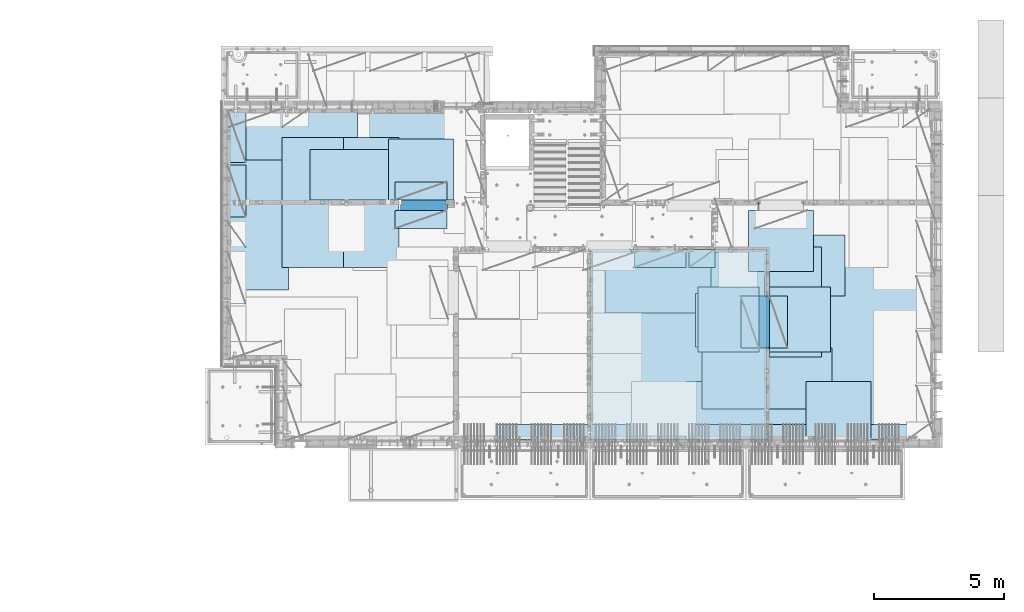
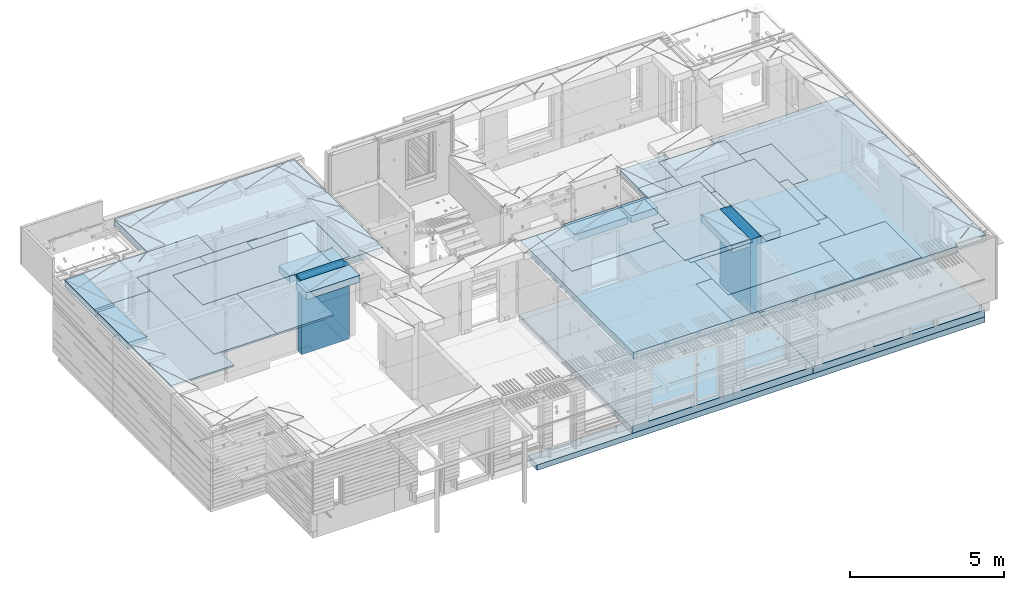
# One storey, part 183 of 325: 26 plates, 6 slabs, 25 elements without a shape of their own.
"""IFC2X3 building model written with IfcOpenShell, lengths in millimetres."""

from ifc_helpers import new_model, si_unit, frame, origin_with_axes, place, context, subcontext, project, spatial, faceted_brep, material, type_object, element, aggregate, save


model = new_model("IFC2X3")

# Units and contexts
model_context = context("Model", 3, precision=1e-05, world=origin_with_axes())
body_context = subcontext(model_context, "Body", "Model", "MODEL_VIEW")
ifc_project = project(units=[si_unit("LENGTHUNIT", "METRE", prefix="MILLI"), si_unit("AREAUNIT", "SQUARE_METRE"), si_unit("VOLUMEUNIT", "CUBIC_METRE"), si_unit("MASSUNIT", "GRAM", prefix="KILO"), si_unit("TIMEUNIT", "SECOND"), si_unit("PLANEANGLEUNIT", "RADIAN"), si_unit("SOLIDANGLEUNIT", "STERADIAN"), si_unit("THERMODYNAMICTEMPERATUREUNIT", "DEGREE_CELSIUS"), si_unit("LUMINOUSINTENSITYUNIT", "LUMEN")], contexts=[model_context])

# Site, building, storey
site_placement = place(None, origin_with_axes())
site = spatial("IfcSite", under=ifc_project, at=site_placement, CompositionType="ELEMENT")
building_placement = place(site_placement, origin_with_axes())
building = spatial("IfcBuilding", under=site, at=building_placement, CompositionType="ELEMENT")
storey_placement = place(building_placement, origin_with_axes())
storey = spatial("IfcBuildingStorey", under=building, at=storey_placement, Name="1", CompositionType="ELEMENT", Elevation=0.0)

# Assembly, slabs
assembly_1_placement = place(storey_placement, origin_with_axes())
assembly_1 = element("IfcElementAssembly", 1, at=assembly_1_placement, inside=storey, AssemblyPlace="NOTDEFINED", PredefinedType="REINFORCEMENT_UNIT")
ifc_material_1 = material(Name="CONCRETE/C30/37")
slab_type_1 = type_object("IfcSlabType", PredefinedType="NOTDEFINED")
slab_1_placement = place(assembly_1_placement, frame((18264.9999999987, 7849.99983252054, 81350.0), z_axis=(0.0, 1.0, 0.0), x_axis=(1.0, 0.0, 0.0)))
slab_1 = element("IfcSlab", 2, at=slab_1_placement, type_object=slab_type_1, material=ifc_material_1, PredefinedType="FLOOR", context=body_context, shape_type="Brep", body=[
    faceted_brep([(-5.0, -109.669999999998, 599.999999999999), (16794.998046875, -109.669999999998, 599.999999999999), (-5.0, 110.0, 379.999999999999), (16794.998046875, 110.0, 379.999999999999), (-5.0, 110.0, -9.09494701772928e-13), (0.0, 110.0, 0.0), (1.81898940354586e-12, -110.000000000058, 0.0), (-5.0, -110.0, -9.09494701772928e-13), (-5.0, -110.0, 379.999999999999), (-5.0, -110.0, 599.999999999999), (16794.998046875, -110.0, 599.999999999999), (16794.998046875, -110.0, 379.999999999999), (16794.998046875, -110.0, 0.0), (16794.998046875, 110.0, 0.0)], [[[0, 1, 2]], [[3, 2, 1]], [[4, 2, 5]], [[5, 2, 3]], [[6, 7, 4, 5]], [[7, 8, 2, 4]], [[8, 9, 0, 2]], [[9, 10, 1, 0]], [[10, 11, 3, 1]], [[11, 12, 13, 3]], [[12, 6, 5, 13]], [[13, 5, 3]], [[12, 11, 10, 9, 8, 7, 6]]]),
])
slab_type_2 = type_object("IfcSlabType", PredefinedType="NOTDEFINED")
slab_2_placement = place(assembly_1_placement, frame((21810.0, 7850.0, 81595.0), z_axis=(0.0, 1.0, 0.0), x_axis=(1.0, 0.0, 0.0)))
slab_2 = element("IfcSlab", 3, at=slab_2_placement, type_object=slab_type_2, material=ifc_material_1, PredefinedType="FLOOR", context=body_context, shape_type="Brep", body=[
    faceted_brep([(1.81898940354586e-12, -135.0, 1.81898940354586e-12), (0.0, -135.0, 7330.0), (0.0, 135.0, 7330.0), (1.81898940354586e-12, 135.0, 1.81898940354586e-12), (6800.0, -135.0, 7330.0), (6800.0, 135.0, 7330.0), (6800.0, -135.0, 0.0), (6800.0, 135.0, 0.0)], [[[0, 1, 2, 3]], [[1, 4, 5, 2]], [[4, 6, 7, 5]], [[6, 0, 3, 7]], [[5, 7, 3, 2]], [[6, 4, 1, 0]]]),
])

assembly_2_placement = place(storey_placement, origin_with_axes())
assembly_2 = element("IfcElementAssembly", 4, at=assembly_2_placement, inside=storey, AssemblyPlace="NOTDEFINED", PredefinedType="REINFORCEMENT_UNIT")
slab_3_placement = place(assembly_2_placement, frame((21810.0, 7750.0, 84595.0), z_axis=(0.0, 1.0, 0.0), x_axis=(1.0, 0.0, 0.0)))
slab_3 = element("IfcSlab", 5, at=slab_3_placement, type_object=slab_type_2, material=ifc_material_1, PredefinedType="FLOOR", context=body_context, shape_type="Brep", body=[
    faceted_brep([(6500.0, -135.0, 5637.99963378906), (6500.0, 135.0, 5637.99963378906), (6500.0, 135.0, 5680.0), (6500.0, -135.0, 5680.0), (6800.0, -135.0, 5680.0), (6800.0, 135.0, 5680.0), (6800.0, -135.0, 3637.99963378906), (6800.0, 135.0, 3637.99963378906), (6500.0, 135.0, 3637.99963378906), (6500.0, -135.0, 3637.99963378906), (6800.0, -135.0, 0.0), (6800.0, 135.0, 0.0), (1.81898940354586e-12, -135.0, 1.81898940354586e-12), (1.81898940354586e-12, 135.0, 1.81898940354586e-12), (0.0, -135.0, 7330.0), (0.0, 135.0, 7330.0), (1569.99914550782, -135.0, 7330.0), (1569.99914550782, 135.0, 7330.0), (1569.99914550782, -135.0, 7430.0), (1569.99914550782, 135.0, 7430.0), (6800.0, -135.0, 7430.0), (6800.0, 135.0, 7430.0), (6500.0, 135.0, 3780.0), (6500.0, -135.0, 3780.0)], [[[0, 1, 2, 3]], [[4, 3, 2, 5]], [[6, 7, 8, 9]], [[10, 11, 7, 6]], [[10, 12, 13, 11]], [[12, 14, 15, 13]], [[16, 17, 15, 14]], [[18, 19, 17, 16]], [[20, 21, 19, 18]], [[21, 20, 4, 5]], [[1, 22, 8, 7, 11, 13, 15, 17, 19, 21, 5, 2]], [[23, 9, 8, 22, 1, 0]], [[20, 18, 16, 14, 12, 10, 6, 9, 23, 0, 3, 4]]]),
])
slab_type_3 = type_object("IfcSlabType", PredefinedType="NOTDEFINED")
slab_4_placement = place(assembly_2_placement, frame((7880.0, 16980.0, 84595.0), z_axis=(0.0, 1.0, 0.0), x_axis=(1.0, 0.0, 0.0)))
slab_4 = element("IfcSlab", 6, at=slab_4_placement, type_object=slab_type_3, material=ifc_material_1, PredefinedType="FLOOR", context=body_context, shape_type="Brep", body=[
    faceted_brep([(6583.68914550781, -135.0, 0.0), (6583.68914550781, 135.0, 0.0), (6583.68914550781, 135.0, 100.0), (6583.68914550781, -135.0, 100.0), (6649.99914550781, -135.0, 99.9997787475586), (6649.99914550781, 135.0, 99.9997787475586), (1.81898940354586e-12, -135.0, 1.81898940354586e-12), (-0.0001220703125, -135.0, 3600.0), (-0.0001220703125, 135.0, 3600.0), (1.81898940354586e-12, 135.0, 1.81898940354586e-12), (3110.00024414063, -135.0, 3600.0), (3110.00024414063, 135.0, 3600.0), (3110.00024414063, -135.0, 5760.0), (3110.00024414063, 135.0, 5760.0), (9850.0009765625, -135.0, 5760.0), (9850.0009765625, 135.0, 5760.0), (9850.0009765625, -135.0, 3600.0), (9850.0009765625, 135.0, 3600.0), (9870.0, -135.0, 3600.0), (9870.0, 135.0, 3600.0), (9870.0, -135.0, 0.0), (9870.0, 135.0, 0.0), (8449.99914550781, -135.0, 0.0), (8449.99914550781, 135.0, 0.0), (8449.99914550781, -135.0, 99.9997787475586), (8449.99914550781, 135.0, 99.9997787475586), (8283.68914550781, -135.0, 99.9997787475586), (8283.68914550781, 135.0, 99.9997787475586)], [[[0, 1, 2, 3]], [[4, 3, 2, 5]], [[6, 7, 8, 9]], [[7, 10, 11, 8]], [[10, 12, 13, 11]], [[12, 14, 15, 13]], [[14, 16, 17, 15]], [[16, 18, 19, 17]], [[18, 20, 21, 19]], [[21, 20, 22, 23]], [[24, 25, 23, 22]], [[26, 4, 5, 27, 25, 24]], [[1, 9, 8, 11, 13, 15, 17, 19, 21, 23, 25, 27, 5, 2]], [[6, 9, 1, 0]], [[26, 24, 22, 20, 18, 16, 14, 12, 10, 7, 6, 0, 3, 4]]]),
])

# Slab
slab_type_4 = type_object("IfcSlabType", PredefinedType="NOTDEFINED")
slab_5_placement = place(assembly_1_placement, frame((28610.0, 7850.0, 81595.0), z_axis=(0.0, 1.0, 0.0), x_axis=(1.0, 0.0, 0.0)))
slab_5 = element("IfcSlab", 7, at=slab_5_placement, type_object=slab_type_4, material=ifc_material_1, PredefinedType="FLOOR", context=body_context, shape_type="Brep", body=[
    faceted_brep([(1.81898940354586e-12, -135.0, 1.81898940354586e-12), (0.0, -135.0, 7330.0), (0.0, 135.0, 7330.0), (1.81898940354586e-12, 135.0, 1.81898940354586e-12), (-1999.99938964843, -135.0, 7330.0), (-1999.99938964843, 135.0, 7330.0), (-1999.99926757812, -135.0, 9130.0), (-1999.99926757812, 135.0, 9130.0), (6449.9990234375, -135.0, 9130.0), (6449.9990234375, 135.0, 9130.0), (6449.9990234375, -135.0, 0.000234620485571213), (6449.9990234375, 135.0, 0.000234620485571213), (5318.0, -135.0, -8.68840288603678e-09), (5318.0, 135.0, -8.68840288603678e-09)], [[[0, 1, 2, 3]], [[1, 4, 5, 2]], [[4, 6, 7, 5]], [[6, 8, 9, 7]], [[8, 10, 11, 9]], [[10, 12, 13, 11]], [[12, 0, 3, 13]], [[5, 7, 9, 11, 13, 3, 2]], [[12, 10, 8, 6, 4, 1, 0]]]),
])

aggregate(assembly_1, [slab_1, slab_2, slab_5])

slab_6_placement = place(assembly_2_placement, frame((28610.0, 7708.0, 84595.0), z_axis=(0.0, 1.0, 0.0), x_axis=(1.0, 0.0, 0.0)))
slab_6 = element("IfcSlab", 8, at=slab_6_placement, type_object=slab_type_4, material=ifc_material_1, PredefinedType="FLOOR", context=body_context, shape_type="Brep", body=[
    faceted_brep([(0.0, -135.0, 7430.0), (0.0, 135.0, 7430.0), (0.0, 135.0, 5722.0), (0.0, -135.0, 5722.0), (-1999.99938964844, -135.0, 7430.0), (-1999.99938964844, 135.0, 7430.0), (-1999.99938964844, -135.0, 9230.0), (-1999.99938964844, 135.0, 9230.0), (-300.000239723071, -135.0, 9230.0), (-300.000239723071, 135.0, 9230.0), (-300.00008947117, -135.0, 8972.00002930513), (-300.00008947117, 135.0, 8972.00002930513), (1385.00027673977, -135.0, 8972.00002930513), (1400.0006429507, -135.0, 8972.00002930513), (1400.0006429507, 135.0, 8972.00002930513), (1385.00027673977, 135.0, 8972.00002930513), (1400.0006429507, -135.0, 9230.0), (1400.0006429507, 135.0, 9230.0), (6449.99951171875, -135.0, 9230.0), (6449.99951171875, 135.0, 9230.0), (6449.99951171875, -135.0, 100.00023651123), (6449.99951171875, 135.0, 100.00023651123), (5318.0, -135.0, 100.0), (5318.0, 135.0, 100.0), (5318.0, -135.0, -8.68840288603678e-09), (5318.0, 135.0, -8.68840288603678e-09), (1.81898940354586e-12, -135.0, 1.81898940354586e-12), (1.81898940354586e-12, 135.0, 1.81898940354586e-12), (0.0, 135.0, 3679.99963378906), (100.00089263916, 135.0, 3679.99963378906), (100.00089263916, 135.0, 3822.0), (100.00089263916, 135.0, 5679.99963378906), (100.00089263916, 135.0, 5722.0), (100.00089263916, -135.0, 5722.0), (100.00089263916, -135.0, 3822.0), (100.00089263916, -135.0, 3679.99963378906), (0.0, -135.0, 3679.99963378906), (100.00089263916, -135.0, 5679.99963378906)], [[[0, 1, 2, 3]], [[0, 4, 5, 1]], [[4, 6, 7, 5]], [[7, 6, 8, 9]], [[8, 10, 11, 9]], [[12, 13, 14, 15, 11, 10]], [[16, 17, 14, 13]], [[18, 19, 17, 16]], [[18, 20, 21, 19]], [[20, 22, 23, 21]], [[22, 24, 25, 23]], [[24, 26, 27, 25]], [[1, 5, 7, 9, 11, 15, 14, 17, 19, 21, 23, 25, 27, 28, 29, 30, 31, 32, 2]], [[3, 2, 32, 33]], [[34, 35, 36, 26, 24, 22, 20, 18, 16, 13, 12, 10, 8, 6, 4, 0, 3, 33, 37]], [[27, 26, 36, 28]], [[35, 29, 28, 36]], [[34, 37, 31, 30, 29, 35]], [[33, 32, 31, 37]]]),
])

# Assembly, plate
assembly_3_placement = place(storey_placement, origin_with_axes())
assembly_3 = element("IfcElementAssembly", 9, at=assembly_3_placement, inside=storey, Name="Steel Assembly", AssemblyPlace="NOTDEFINED", PredefinedType="NOTDEFINED")
ifc_material_2 = material()
plate_type_1 = type_object("IfcPlateType", PredefinedType="NOTDEFINED")
plate_1_placement = place(assembly_3_placement, frame((27902.5000293051, 16680.0, 84695.1), z_axis=(1.0, 0.0, 0.0), x_axis=(0.0, -1.0, 0.0)))
plate_1 = element("IfcPlate", 10, at=plate_1_placement, type_object=plate_type_1, material=ifc_material_2, Name="1/2", context=body_context, shape_type="Brep", body=[
    faceted_brep([(0.0, -35.0, 0.0), (0.0, -35.0, 2500.0), (0.0, 35.0, 2500.0), (0.0, 35.0, 0.0), (2349.99951171875, -35.0, 2500.0), (2349.99951171875, 35.0, 2500.0), (2350.0, -35.0, 0.0), (2350.0, 35.0, 0.0)], [[[0, 1, 2, 3]], [[1, 4, 5, 2]], [[4, 6, 7, 5]], [[6, 0, 3, 7]], [[5, 7, 3, 2]], [[6, 4, 1, 0]]]),
])
aggregate(assembly_3, [plate_1])

assembly_4_placement = place(storey_placement, origin_with_axes())
assembly_4 = element("IfcElementAssembly", 11, at=assembly_4_placement, inside=storey, Name="Steel Assembly", AssemblyPlace="NOTDEFINED", PredefinedType="NOTDEFINED")
plate_2_placement = place(assembly_4_placement, frame((32610.0, 7750.0, 84695.1), z_axis=(-1.0, 3.00000001838171e-08, 0.0), x_axis=(0.0, 1.0, 0.0)))
plate_2 = element("IfcPlate", 12, at=plate_2_placement, type_object=plate_type_1, material=ifc_material_2, Name="1/2", context=body_context, shape_type="Brep", body=[
    faceted_brep([(0.0, -35.0, 0.0), (0.0, -35.0, 2500.0), (0.0, 35.0, 2500.0), (0.0, 35.0, 0.0), (2349.99951171875, -35.0, 2500.0), (2349.99951171875, 35.0, 2500.0), (2350.0, -35.0, 0.0), (2350.0, 35.0, 0.0)], [[[0, 1, 2, 3]], [[1, 4, 5, 2]], [[4, 6, 7, 5]], [[6, 0, 3, 7]], [[5, 7, 3, 2]], [[6, 4, 1, 0]]]),
])
aggregate(assembly_4, [plate_2])

assembly_5_placement = place(storey_placement, origin_with_axes())
assembly_5 = element("IfcElementAssembly", 13, at=assembly_5_placement, inside=storey, Name="Steel Assembly", AssemblyPlace="NOTDEFINED", PredefinedType="NOTDEFINED")
plate_3_placement = place(assembly_5_placement, frame((27395.0, 12730.0, 84695.1), z_axis=(-1.0, 3.00000001838171e-08, 0.0), x_axis=(0.0, 1.0, 0.0)))
plate_3 = element("IfcPlate", 14, at=plate_3_placement, type_object=plate_type_1, material=ifc_material_2, context=body_context, shape_type="Brep", body=[
    faceted_brep([(0.0, -35.0, 0.0), (0.0, -35.0, 5000.0), (0.0, 35.0, 5000.0), (0.0, 35.0, 0.0), (2349.99951171875, -35.0, 5000.0), (2349.99951171875, 35.0, 5000.0), (2350.0, -35.0, 0.0), (2350.0, 35.0, 0.0)], [[[0, 1, 2, 3]], [[1, 4, 5, 2]], [[4, 6, 7, 5]], [[6, 0, 3, 7]], [[5, 7, 3, 2]], [[6, 4, 1, 0]]]),
])
aggregate(assembly_5, [plate_3])

assembly_6_placement = place(storey_placement, origin_with_axes())
assembly_6 = element("IfcElementAssembly", 15, at=assembly_6_placement, inside=storey, Name="Steel Assembly", AssemblyPlace="NOTDEFINED", PredefinedType="NOTDEFINED")
plate_4_placement = place(assembly_6_placement, frame((28709.9995320312, 11230.0000289158, 84695.1), z_axis=(0.0, 1.0, 0.0), x_axis=(1.0, 0.0, 0.0)))
plate_4 = element("IfcPlate", 16, at=plate_4_placement, type_object=plate_type_1, material=ifc_material_2, Name="1/2", context=body_context, shape_type="Brep", body=[
    faceted_brep([(0.0, -35.0, 0.0), (0.0, -35.0, 2500.0), (0.0, 35.0, 2500.0), (0.0, 35.0, 0.0), (2349.99951171875, -35.0, 2500.0), (2349.99951171875, 35.0, 2500.0), (2350.0, -35.0, 0.0), (2350.0, 35.0, 0.0)], [[[0, 1, 2, 3]], [[1, 4, 5, 2]], [[4, 6, 7, 5]], [[6, 0, 3, 7]], [[5, 7, 3, 2]], [[6, 4, 1, 0]]]),
])
aggregate(assembly_6, [plate_4])

assembly_7_placement = place(storey_placement, origin_with_axes())
assembly_7 = element("IfcElementAssembly", 17, at=assembly_7_placement, inside=storey, Name="Steel Assembly", AssemblyPlace="NOTDEFINED", PredefinedType="NOTDEFINED")
plate_5_placement = place(assembly_7_placement, frame((25959.9995320312, 11230.0000289158, 84695.1), z_axis=(0.0, 1.0, 0.0), x_axis=(1.0, 0.0, 0.0)))
plate_5 = element("IfcPlate", 18, at=plate_5_placement, type_object=plate_type_1, material=ifc_material_2, Name="1/2", context=body_context, shape_type="Brep", body=[
    faceted_brep([(0.0, -35.0, 0.0), (0.0, -35.0, 2500.0), (0.0, 35.0, 2500.0), (0.0, 35.0, 0.0), (2349.99951171875, -35.0, 2500.0), (2349.99951171875, 35.0, 2500.0), (2350.0, -35.0, 0.0), (2350.0, 35.0, 0.0)], [[[0, 1, 2, 3]], [[1, 4, 5, 2]], [[4, 6, 7, 5]], [[6, 0, 3, 7]], [[5, 7, 3, 2]], [[6, 4, 1, 0]]]),
])
aggregate(assembly_7, [plate_5])

assembly_8_placement = place(storey_placement, origin_with_axes())
assembly_8 = element("IfcElementAssembly", 19, at=assembly_8_placement, inside=storey, Name="Steel Assembly", AssemblyPlace="NOTDEFINED", PredefinedType="NOTDEFINED")
plate_6_placement = place(assembly_8_placement, frame((7880.0, 20580.0, 84695.1), z_axis=(1.0, 0.0, 0.0), x_axis=(0.0, -1.0, 0.0)))
plate_6 = element("IfcPlate", 20, at=plate_6_placement, type_object=plate_type_1, material=ifc_material_2, context=body_context, shape_type="Brep", body=[
    faceted_brep([(0.0, -35.0, 0.0), (0.0, -35.0, 5000.0), (0.0, 35.0, 5000.0), (0.0, 35.0, 0.0), (2349.99951171875, -35.0, 5000.0), (2349.99951171875, 35.0, 5000.0), (2350.0, -35.0, 0.0), (2350.0, 35.0, 0.0)], [[[0, 1, 2, 3]], [[1, 4, 5, 2]], [[4, 6, 7, 5]], [[6, 0, 3, 7]], [[5, 7, 3, 2]], [[6, 4, 1, 0]]]),
])
aggregate(assembly_8, [plate_6])

assembly_9_placement = place(storey_placement, origin_with_axes())
assembly_9 = element("IfcElementAssembly", 21, at=assembly_9_placement, inside=storey, Name="Steel Assembly", AssemblyPlace="NOTDEFINED", PredefinedType="NOTDEFINED")
plate_7_placement = place(assembly_9_placement, frame((14063.69, 19430.0, 84695.1), z_axis=(1.0, 0.0, 0.0), x_axis=(0.0, -1.0, 0.0)))
plate_7 = element("IfcPlate", 22, at=plate_7_placement, type_object=plate_type_1, material=ifc_material_2, Name="1/2", context=body_context, shape_type="Brep", body=[
    faceted_brep([(0.0, -35.0, 0.0), (0.0, -35.0, 2500.0), (0.0, 35.0, 2500.0), (0.0, 35.0, 0.0), (2349.99951171875, -35.0, 2500.0), (2349.99951171875, 35.0, 2500.0), (2350.0, -35.0, 0.0), (2350.0, 35.0, 0.0)], [[[0, 1, 2, 3]], [[1, 4, 5, 2]], [[4, 6, 7, 5]], [[6, 0, 3, 7]], [[5, 7, 3, 2]], [[6, 4, 1, 0]]]),
])
aggregate(assembly_9, [plate_7])

assembly_10_placement = place(storey_placement, origin_with_axes())
assembly_10 = element("IfcElementAssembly", 23, at=assembly_10_placement, inside=storey, Name="Steel Assembly", AssemblyPlace="NOTDEFINED", PredefinedType="NOTDEFINED")
plate_8_placement = place(assembly_10_placement, frame((31610.0, 13388.0, 84695.1), z_axis=(-1.0, 3.00000001838171e-08, 0.0), x_axis=(0.0, 1.0, 0.0)))
plate_8 = element("IfcPlate", 24, at=plate_8_placement, type_object=plate_type_1, material=ifc_material_2, context=body_context, shape_type="Brep", body=[
    faceted_brep([(0.0, -35.0, 0.0), (0.0, -35.0, 5000.0), (0.0, 35.0, 5000.0), (0.0, 35.0, 0.0), (2349.99951171875, -35.0, 5000.0), (2349.99951171875, 35.0, 5000.0), (2350.0, -35.0, 0.0), (2350.0, 35.0, 0.0)], [[[0, 1, 2, 3]], [[1, 4, 5, 2]], [[4, 6, 7, 5]], [[6, 0, 3, 7]], [[5, 7, 3, 2]], [[6, 4, 1, 0]]]),
])
aggregate(assembly_10, [plate_8])

assembly_11_placement = place(storey_placement, origin_with_axes())
assembly_11 = element("IfcElementAssembly", 25, at=assembly_11_placement, inside=storey, Name="Steel Assembly", AssemblyPlace="NOTDEFINED", PredefinedType="NOTDEFINED")
plate_9_placement = place(assembly_11_placement, frame((31110.0, 9038.0, 84695.1), z_axis=(-1.0, 3.00000001838171e-08, 0.0), x_axis=(0.0, 1.0, 0.0)))
plate_9 = element("IfcPlate", 26, at=plate_9_placement, type_object=plate_type_1, material=ifc_material_2, context=body_context, shape_type="Brep", body=[
    faceted_brep([(0.0, -35.0, 0.0), (0.0, -35.0, 5000.0), (0.0, 35.0, 5000.0), (0.0, 35.0, 0.0), (2349.99951171875, -35.0, 5000.0), (2349.99951171875, 35.0, 5000.0), (2350.0, -35.0, 0.0), (2350.0, 35.0, 0.0)], [[[0, 1, 2, 3]], [[1, 4, 5, 2]], [[4, 6, 7, 5]], [[6, 0, 3, 7]], [[5, 7, 3, 2]], [[6, 4, 1, 0]]]),
])
aggregate(assembly_11, [plate_9])

assembly_12_placement = place(storey_placement, origin_with_axes())
assembly_12 = element("IfcElementAssembly", 27, at=assembly_12_placement, inside=storey, Name="Steel Assembly", AssemblyPlace="NOTDEFINED", PredefinedType="NOTDEFINED")
plate_10_placement = place(assembly_12_placement, frame((30510.0, 7750.0, 84695.1), z_axis=(-1.0, 3.00000001838171e-08, 0.0), x_axis=(0.0, 1.0, 0.0)))
plate_10 = element("IfcPlate", 28, at=plate_10_placement, type_object=plate_type_1, material=ifc_material_2, context=body_context, shape_type="Brep", body=[
    faceted_brep([(0.0, -35.0, 0.0), (0.0, -35.0, 5000.0), (0.0, 35.0, 5000.0), (0.0, 35.0, 0.0), (2349.99951171875, -35.0, 5000.0), (2349.99951171875, 35.0, 5000.0), (2350.0, -35.0, 0.0), (2350.0, 35.0, 0.0)], [[[0, 1, 2, 3]], [[1, 4, 5, 2]], [[4, 6, 7, 5]], [[6, 0, 3, 7]], [[5, 7, 3, 2]], [[6, 4, 1, 0]]]),
])
aggregate(assembly_12, [plate_10])

assembly_13_placement = place(storey_placement, origin_with_axes())
assembly_13 = element("IfcElementAssembly", 29, at=assembly_13_placement, inside=storey, Name="Steel Assembly", AssemblyPlace="NOTDEFINED", PredefinedType="NOTDEFINED")
plate_11_placement = place(assembly_13_placement, frame((10230.0, 18627.0, 84695.1), z_axis=(0.0, -1.0, 0.0), x_axis=(-1.0, 3.00000001838171e-08, 0.0)))
plate_11 = element("IfcPlate", 30, at=plate_11_placement, type_object=plate_type_1, material=ifc_material_2, context=body_context, shape_type="Brep", body=[
    faceted_brep([(0.0, -35.0, 0.0), (0.0, -35.0, 5000.0), (0.0, 35.0, 5000.0), (0.0, 35.0, 0.0), (2349.99951171875, -35.0, 5000.0), (2349.99951171875, 35.0, 5000.0), (2350.0, -35.0, 0.0), (2350.0, 35.0, 0.0)], [[[0, 1, 2, 3]], [[1, 4, 5, 2]], [[4, 6, 7, 5]], [[6, 0, 3, 7]], [[5, 7, 3, 2]], [[6, 4, 1, 0]]]),
])
aggregate(assembly_13, [plate_11])

assembly_14_placement = place(storey_placement, origin_with_axes())
assembly_14 = element("IfcElementAssembly", 31, at=assembly_14_placement, inside=storey, Name="Steel Assembly", AssemblyPlace="NOTDEFINED", PredefinedType="NOTDEFINED")
plate_12_placement = place(assembly_14_placement, frame((14463.69, 19480.0, 84695.1), z_axis=(0.0, -1.0, 0.0), x_axis=(-1.0, 3.00000001838171e-08, 0.0)))
plate_12 = element("IfcPlate", 32, at=plate_12_placement, type_object=plate_type_1, material=ifc_material_2, context=body_context, shape_type="Brep", body=[
    faceted_brep([(0.0, -35.0, 0.0), (0.0, -35.0, 5000.0), (0.0, 35.0, 5000.0), (0.0, 35.0, 0.0), (2349.99951171875, -35.0, 5000.0), (2349.99951171875, 35.0, 5000.0), (2350.0, -35.0, 0.0), (2350.0, 35.0, 0.0)], [[[0, 1, 2, 3]], [[1, 4, 5, 2]], [[4, 6, 7, 5]], [[6, 0, 3, 7]], [[5, 7, 3, 2]], [[6, 4, 1, 0]]]),
])
aggregate(assembly_14, [plate_12])

assembly_15_placement = place(storey_placement, origin_with_axes())
assembly_15 = element("IfcElementAssembly", 33, at=assembly_15_placement, inside=storey, Name="Steel Assembly", AssemblyPlace="NOTDEFINED", PredefinedType="NOTDEFINED")
plate_13_placement = place(assembly_15_placement, frame((12330.0, 19480.0, 84695.1), z_axis=(0.0, -1.0, 0.0), x_axis=(-1.0, 3.00000001838171e-08, 0.0)))
plate_13 = element("IfcPlate", 34, at=plate_13_placement, type_object=plate_type_1, material=ifc_material_2, context=body_context, shape_type="Brep", body=[
    faceted_brep([(0.0, -35.0, 0.0), (0.0, -35.0, 5000.0), (0.0, 35.0, 5000.0), (0.0, 35.0, 0.0), (2349.99951171875, -35.0, 5000.0), (2349.99951171875, 35.0, 5000.0), (2350.0, -35.0, 0.0), (2350.0, 35.0, 0.0)], [[[0, 1, 2, 3]], [[1, 4, 5, 2]], [[4, 6, 7, 5]], [[6, 0, 3, 7]], [[5, 7, 3, 2]], [[6, 4, 1, 0]]]),
])
aggregate(assembly_15, [plate_13])

assembly_16_placement = place(storey_placement, origin_with_axes())
assembly_16 = element("IfcElementAssembly", 35, at=assembly_16_placement, inside=storey, Name="Steel Assembly", AssemblyPlace="NOTDEFINED", PredefinedType="NOTDEFINED")
plate_type_2 = type_object("IfcPlateType", PredefinedType="NOTDEFINED")
plate_14_placement = place(assembly_16_placement, frame((7879.99987792969, 20530.0, 84595.3), z_axis=(1.0, 0.0, 0.0), x_axis=(0.0, -1.0, 0.0)))
plate_14 = element("IfcPlate", 36, at=plate_14_placement, type_object=plate_type_2, material=ifc_material_2, Name="RE1", context=body_context, shape_type="Brep", body=[
    faceted_brep([(1.81898940354586e-12, -135.0, 1.81898940354586e-12), (0.0, -135.0, 699.999999999996), (0.0, 135.0, 699.999999999996), (1.81898940354586e-12, 135.0, 1.81898940354586e-12), (1999.99951171875, -135.0, 699.999999999993), (1999.99951171875, 135.0, 699.999999999993), (2000.0, -135.0, -3.63797880709171e-12), (2000.0, 135.0, -3.63797880709171e-12)], [[[0, 1, 2, 3]], [[1, 4, 5, 2]], [[4, 6, 7, 5]], [[6, 0, 3, 7]], [[5, 7, 3, 2]], [[6, 4, 1, 0]]]),
])
aggregate(assembly_16, [plate_14])

assembly_17_placement = place(storey_placement, origin_with_axes())
assembly_17 = element("IfcElementAssembly", 37, at=assembly_17_placement, inside=storey, Name="Steel Assembly", AssemblyPlace="NOTDEFINED", PredefinedType="NOTDEFINED")
plate_15_placement = place(assembly_17_placement, frame((28710.2298779297, 13388.0, 84595.3), z_axis=(1.0, 0.0, 0.0), x_axis=(0.0, -1.0, 0.0)))
plate_15 = element("IfcPlate", 38, at=plate_15_placement, type_object=plate_type_2, material=ifc_material_2, Name="RE1", context=body_context, shape_type="Brep", body=[
    faceted_brep([(1.81898940354586e-12, -135.0, 1.81898940354586e-12), (0.0, -135.0, 699.999999999996), (0.0, 135.0, 699.999999999996), (1.81898940354586e-12, 135.0, 1.81898940354586e-12), (1999.99951171875, -135.0, 699.999999999993), (1999.99951171875, 135.0, 699.999999999993), (2000.0, -135.0, -3.63797880709171e-12), (2000.0, 135.0, -3.63797880709171e-12)], [[[0, 1, 2, 3]], [[1, 4, 5, 2]], [[4, 6, 7, 5]], [[6, 0, 3, 7]], [[5, 7, 3, 2]], [[6, 4, 1, 0]]]),
])
aggregate(assembly_17, [plate_15])

assembly_18_placement = place(storey_placement, origin_with_axes())
assembly_18 = element("IfcElementAssembly", 39, at=assembly_18_placement, inside=storey, Name="Steel Assembly", AssemblyPlace="NOTDEFINED", PredefinedType="NOTDEFINED")
plate_16_placement = place(assembly_18_placement, frame((28310.0001220703, 11388.0, 84595.3), z_axis=(-1.0, 3.00000001838171e-08, 0.0), x_axis=(0.0, 1.0, 0.0)))
plate_16 = element("IfcPlate", 40, at=plate_16_placement, type_object=plate_type_2, material=ifc_material_2, Name="RE1", context=body_context, shape_type="Brep", body=[
    faceted_brep([(1.81898940354586e-12, -135.0, 1.81898940354586e-12), (0.0, -135.0, 699.999999999996), (0.0, 135.0, 699.999999999996), (1.81898940354586e-12, 135.0, 1.81898940354586e-12), (1999.99951171875, -135.0, 699.999999999993), (1999.99951171875, 135.0, 699.999999999993), (2000.0, -135.0, -3.63797880709171e-12), (2000.0, 135.0, -3.63797880709171e-12)], [[[0, 1, 2, 3]], [[1, 4, 5, 2]], [[4, 6, 7, 5]], [[6, 0, 3, 7]], [[5, 7, 3, 2]], [[6, 4, 1, 0]]]),
])
aggregate(assembly_18, [plate_16])

assembly_19_placement = place(storey_placement, origin_with_axes())
assembly_19 = element("IfcElementAssembly", 41, at=assembly_19_placement, inside=storey, Name="Steel Assembly", AssemblyPlace="NOTDEFINED", PredefinedType="NOTDEFINED")
plate_17_placement = place(assembly_19_placement, frame((14313.6908542386, 17080.0001036336, 84595.3), z_axis=(0.0, 1.0, 0.0), x_axis=(1.0, 0.0, 0.0)))
plate_17 = element("IfcPlate", 42, at=plate_17_placement, type_object=plate_type_2, material=ifc_material_2, Name="RE1", context=body_context, shape_type="Brep", body=[
    faceted_brep([(1.81898940354586e-12, -135.0, 1.81898940354586e-12), (0.0, -135.0, 699.999999999996), (0.0, 135.0, 699.999999999996), (1.81898940354586e-12, 135.0, 1.81898940354586e-12), (1999.99951171875, -135.0, 699.999999999993), (1999.99951171875, 135.0, 699.999999999993), (2000.0, -135.0, -3.63797880709171e-12), (2000.0, 135.0, -3.63797880709171e-12)], [[[0, 1, 2, 3]], [[1, 4, 5, 2]], [[4, 6, 7, 5]], [[6, 0, 3, 7]], [[5, 7, 3, 2]], [[6, 4, 1, 0]]]),
])
aggregate(assembly_19, [plate_17])

assembly_20_placement = place(storey_placement, origin_with_axes())
assembly_20 = element("IfcElementAssembly", 43, at=assembly_20_placement, inside=storey, Name="Steel Assembly", AssemblyPlace="NOTDEFINED", PredefinedType="NOTDEFINED")
plate_18_placement = place(assembly_20_placement, frame((16313.6891457614, 16679.9998963664, 84595.3), z_axis=(0.0, -1.0, 0.0), x_axis=(-1.0, 3.00000001838171e-08, 0.0)))
plate_18 = element("IfcPlate", 44, at=plate_18_placement, type_object=plate_type_2, material=ifc_material_2, Name="RE1", context=body_context, shape_type="Brep", body=[
    faceted_brep([(1.81898940354586e-12, -135.0, 1.81898940354586e-12), (0.0, -135.0, 699.999999999996), (0.0, 135.0, 699.999999999996), (1.81898940354586e-12, 135.0, 1.81898940354586e-12), (1999.99951171875, -135.0, 699.999999999993), (1999.99951171875, 135.0, 699.999999999993), (2000.0, -135.0, -3.63797880709171e-12), (2000.0, 135.0, -3.63797880709171e-12)], [[[0, 1, 2, 3]], [[1, 4, 5, 2]], [[4, 6, 7, 5]], [[6, 0, 3, 7]], [[5, 7, 3, 2]], [[6, 4, 1, 0]]]),
])
aggregate(assembly_20, [plate_18])

assembly_21_placement = place(storey_placement, origin_with_axes())
assembly_21 = element("IfcElementAssembly", 45, at=assembly_21_placement, inside=storey, Name="Steel Assembly", AssemblyPlace="NOTDEFINED", PredefinedType="NOTDEFINED")
plate_19_placement = place(assembly_21_placement, frame((25494.9991457614, 15179.9998963664, 84595.3), z_axis=(0.0, -1.0, 0.0), x_axis=(-1.0, 3.00000001838171e-08, 0.0)))
plate_19 = element("IfcPlate", 46, at=plate_19_placement, type_object=plate_type_2, material=ifc_material_2, Name="RE1", context=body_context, shape_type="Brep", body=[
    faceted_brep([(1.81898940354586e-12, -135.0, 1.81898940354586e-12), (0.0, -135.0, 699.999999999996), (0.0, 135.0, 699.999999999996), (1.81898940354586e-12, 135.0, 1.81898940354586e-12), (1999.99951171875, -135.0, 699.999999999993), (1999.99951171875, 135.0, 699.999999999993), (2000.0, -135.0, -3.63797880709171e-12), (2000.0, 135.0, -3.63797880709171e-12)], [[[0, 1, 2, 3]], [[1, 4, 5, 2]], [[4, 6, 7, 5]], [[6, 0, 3, 7]], [[5, 7, 3, 2]], [[6, 4, 1, 0]]]),
])
aggregate(assembly_21, [plate_19])

assembly_22_placement = place(storey_placement, origin_with_axes())
assembly_22 = element("IfcElementAssembly", 47, at=assembly_22_placement, inside=storey, Name="Steel Assembly", AssemblyPlace="NOTDEFINED", PredefinedType="NOTDEFINED")
plate_20_placement = place(assembly_22_placement, frame((26610.0, 15180.0000000707, 84595.3), z_axis=(0.0, -1.0, 0.0), x_axis=(-1.0, 3.00000001838171e-08, 0.0)))
plate_20 = element("IfcPlate", 48, at=plate_20_placement, type_object=plate_type_2, material=ifc_material_2, Name="RE1_1/2", context=body_context, shape_type="Brep", body=[
    faceted_brep([(1.81898940354586e-12, -135.0, 1.81898940354586e-12), (0.0, -135.0, 699.999999999996), (0.0, 135.0, 699.999999999996), (1.81898940354586e-12, 135.0, 1.81898940354586e-12), (999.99951171875, -135.0, 700.0), (999.99951171875, 135.0, 700.0), (1000.0, -135.0, 0.0), (1000.0, 135.0, 0.0)], [[[0, 1, 2, 3]], [[1, 4, 5, 2]], [[4, 6, 7, 5]], [[6, 0, 3, 7]], [[5, 7, 3, 2]], [[6, 4, 1, 0]]]),
])
aggregate(assembly_22, [plate_20])

assembly_23_placement = place(storey_placement, origin_with_axes())
assembly_23 = element("IfcElementAssembly", 49, at=assembly_23_placement, inside=storey, Name="Steel Assembly", AssemblyPlace="NOTDEFINED", PredefinedType="NOTDEFINED")
plate_21_placement = place(assembly_23_placement, frame((7879.99987792969, 18430.0, 84595.3), z_axis=(1.0, 0.0, 0.0), x_axis=(0.0, -1.0, 0.0)))
plate_21 = element("IfcPlate", 50, at=plate_21_placement, type_object=plate_type_2, material=ifc_material_2, Name="RE1", context=body_context, shape_type="Brep", body=[
    faceted_brep([(1.81898940354586e-12, -135.0, 1.81898940354586e-12), (0.0, -135.0, 699.999999999996), (0.0, 135.0, 699.999999999996), (1.81898940354586e-12, 135.0, 1.81898940354586e-12), (1999.99951171875, -135.0, 699.999999999993), (1999.99951171875, 135.0, 699.999999999993), (2000.0, -135.0, -3.63797880709171e-12), (2000.0, 135.0, -3.63797880709171e-12)], [[[0, 1, 2, 3]], [[1, 4, 5, 2]], [[4, 6, 7, 5]], [[6, 0, 3, 7]], [[5, 7, 3, 2]], [[6, 4, 1, 0]]]),
])
aggregate(assembly_23, [plate_21])

# Plate
plate_type_3 = type_object("IfcPlateType", PredefinedType="NOTDEFINED")
plate_22_placement = place(assembly_2_placement, frame((11048.0003525539, 17079.9997757405, 84725.45), z_axis=(0.0, 1.0, 0.0), x_axis=(1.0, 0.0, 0.0)))
plate_22 = element("IfcPlate", 51, at=plate_22_placement, type_object=plate_type_3, material=ifc_material_2, context=body_context, shape_type="Brep", body=[
    faceted_brep([(0.0, -5.0, 0.0), (0.0, -5.0, 1939.99963378906), (0.0, 5.0, 1939.99963378906), (0.0, 5.0, 0.0), (4827.9990234375, -5.0, 1939.99963378906), (4827.9990234375, 5.0, 1939.99963378906), (4827.9990234375, -5.0, 0.0), (4827.9990234375, 5.0, 0.0)], [[[0, 1, 2, 3]], [[1, 4, 5, 2]], [[4, 6, 7, 5]], [[6, 0, 3, 7]], [[5, 7, 3, 2]], [[6, 4, 1, 0]]]),
])

plate_type_4 = type_object("IfcPlateType", PredefinedType="NOTDEFINED")
plate_23_placement = place(assembly_2_placement, frame((28710.0010086818, 11039.9998138874, 84725.45), z_axis=(0.0, 1.0, 0.0), x_axis=(1.0, 0.0, 0.0)))
plate_23 = element("IfcPlate", 52, at=plate_23_placement, type_object=plate_type_4, material=ifc_material_2, context=body_context, shape_type="Brep", body=[
    faceted_brep([(0.0, -5.0, 0.0), (-0.00100868183653802, -5.0, 4240.0), (-0.00100868183653802, 5.0, 4240.0), (0.0, 5.0, 0.0), (2000.0, -5.0, 4240.0), (2000.0, 5.0, 4240.0), (2000.0, -5.0, 0.0), (2000.0, 5.0, 0.0)], [[[0, 1, 2, 3]], [[1, 4, 5, 2]], [[4, 6, 7, 5]], [[6, 0, 3, 7]], [[5, 7, 3, 2]], [[6, 4, 1, 0]]]),
])

plate_type_5 = type_object("IfcPlateType", PredefinedType="NOTDEFINED")
plate_24_placement = place(assembly_2_placement, frame((25860.0006272121, 11525.9998749226, 84725.45), z_axis=(1.0, 0.0, 0.0), x_axis=(0.0, -1.0, 0.0)))
plate_24 = element("IfcPlate", 53, at=plate_24_placement, type_object=plate_type_5, material=ifc_material_2, context=body_context, shape_type="Brep", body=[
    faceted_brep([(92.0000076293945, -5.0, 2449.99937278789), (92.0000076293945, 5.0, 2449.99937278789), (-1861.99975886647, 5.0, 2449.99937278789), (-1861.99975886647, -5.0, 2449.99937278789), (-1861.99975886647, -5.0, 2649.99937278789), (-1861.99975886647, 5.0, 2649.99939842034), (92.0000076293945, -5.0, 0.0), (0.0, -5.0, 0.0), (0.0, 5.0, 0.0), (92.0000076293945, 5.0, 0.0), (-1954.00048828125, -5.0, 0.0), (-1954.00048828125, 5.0, 0.0), (-1954.00048828125, -5.0, 600.000366210938), (-1954.00048828125, 5.0, 600.000366210938), (-3554.0, -5.0, 600.000366210938), (-3554.0, 5.0, 600.000366210938), (-3554.0, -5.0, 2649.99951171875), (-3554.0, 5.0, 2649.99951171875)], [[[0, 1, 2, 3]], [[4, 3, 2, 5]], [[6, 7, 8, 9]], [[7, 10, 11, 8]], [[10, 12, 13, 11]], [[12, 14, 15, 13]], [[14, 16, 17, 15]], [[17, 16, 4, 5]], [[1, 9, 8, 11, 13, 15, 17, 5, 2]], [[6, 9, 1, 0]], [[16, 14, 12, 10, 7, 6, 0, 3, 4]]]),
])

aggregate(assembly_2, [plate_23, plate_24, plate_22, slab_6, slab_3, slab_4])

# Assembly, plate
assembly_24_placement = place(storey_placement, origin_with_axes())
assembly_24 = element("IfcElementAssembly", 54, at=assembly_24_placement, inside=storey, Name="Steel Assembly", AssemblyPlace="NOTDEFINED", PredefinedType="NOTDEFINED")
ifc_material_3 = material()
plate_type_6 = type_object("IfcPlateType", PredefinedType="NOTDEFINED")
plate_25_placement = place(assembly_24_placement, frame((14530.0, 16680.0, 83255.6000003815), z_axis=(0.0, 1.0, 0.0), x_axis=(1.0, 0.0, 0.0)))
plate_25 = element("IfcPlate", 55, at=plate_25_placement, type_object=plate_type_6, material=ifc_material_3, context=body_context, shape_type="Brep", body=[
    faceted_brep([(1749.99914550781, -1475.0, 400.0), (1749.99914550781, -1475.0, 243.000000000004), (1749.99914550781, 1475.0, 243.000000000004), (1749.99914550781, 1475.0, 400.0), (1799.99914550781, -1475.0, 221.333333333332), (1799.99914550781, 1475.0, 221.333333333332), (30.0, -1475.0, 400.0), (30.0, 1475.0, 400.0), (30.0, 1475.0, 243.0), (30.0, -1475.0, 243.0), (0.0, 1475.0, 230.0), (0.0, -1475.0, 230.0), (0.0, 1475.0, 0.0), (0.0, -1475.0, 0.0), (1799.99914550781, -1475.0, 3.63797880709171e-12), (1799.99914550781, 1475.0, 3.63797880709171e-12)], [[[0, 1, 2, 3]], [[4, 5, 2, 1]], [[6, 7, 8, 9]], [[9, 8, 10, 11]], [[12, 13, 11, 10]], [[14, 13, 12, 15]], [[0, 6, 9, 11, 13, 14, 4, 1]], [[7, 6, 0, 3]], [[15, 12, 10, 8, 7, 3, 2, 5]], [[14, 15, 5, 4]]]),
])
aggregate(assembly_24, [plate_25])

assembly_25_placement = place(storey_placement, origin_with_axes())
assembly_25 = element("IfcElementAssembly", 56, at=assembly_25_placement, inside=storey, Name="Steel Assembly", AssemblyPlace="NOTDEFINED", PredefinedType="NOTDEFINED")
plate_26_placement = place(assembly_25_placement, frame((28710.0, 11388.0, 83255.6000003815), z_axis=(-1.0, 3.00000001838171e-08, 0.0), x_axis=(0.0, 1.0, 0.0)))
plate_26 = element("IfcPlate", 57, at=plate_26_placement, type_object=plate_type_6, material=ifc_material_3, context=body_context, shape_type="Brep", body=[
    faceted_brep([(0.0, -1475.0, 170.000000230655), (0.0, 1475.0, 170.000000368096), (30.0, 1475.0, 156.999999999998), (30.0, -1475.0, 156.999999999998), (29.9999998430139, -1475.0, 0.0), (29.9999998430139, 1475.0, 0.0), (0.0, -1475.0, 400.0), (1999.99963378906, -1475.0, 400.0), (1999.99963378906, 1475.0, 400.0), (0.0, 1475.0, 400.0), (1999.99963378906, -1475.0, 170.000003831468), (1999.99963378906, 1475.0, 170.000003831468), (1969.99962494722, -1475.0, 157.0), (1969.99962494722, 1475.0, 157.0), (1969.99962494722, -1475.0, 0.0), (1969.99962494722, 1475.0, 0.0)], [[[0, 1, 2, 3]], [[4, 3, 2, 5]], [[6, 7, 8, 9]], [[8, 7, 10, 11]], [[12, 13, 11, 10]], [[14, 15, 13, 12]], [[15, 14, 4, 5]], [[1, 9, 8, 11, 13, 15, 5, 2]], [[6, 9, 1, 0]], [[14, 12, 10, 7, 6, 0, 3, 4]]]),
])
aggregate(assembly_25, [plate_26])

save(model, "model.ifc")
